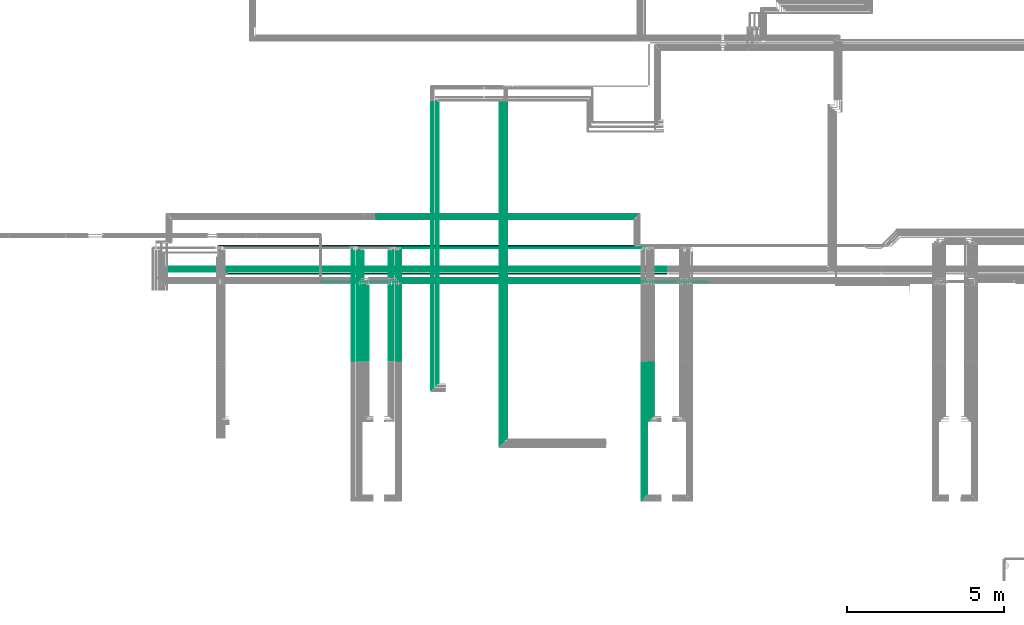
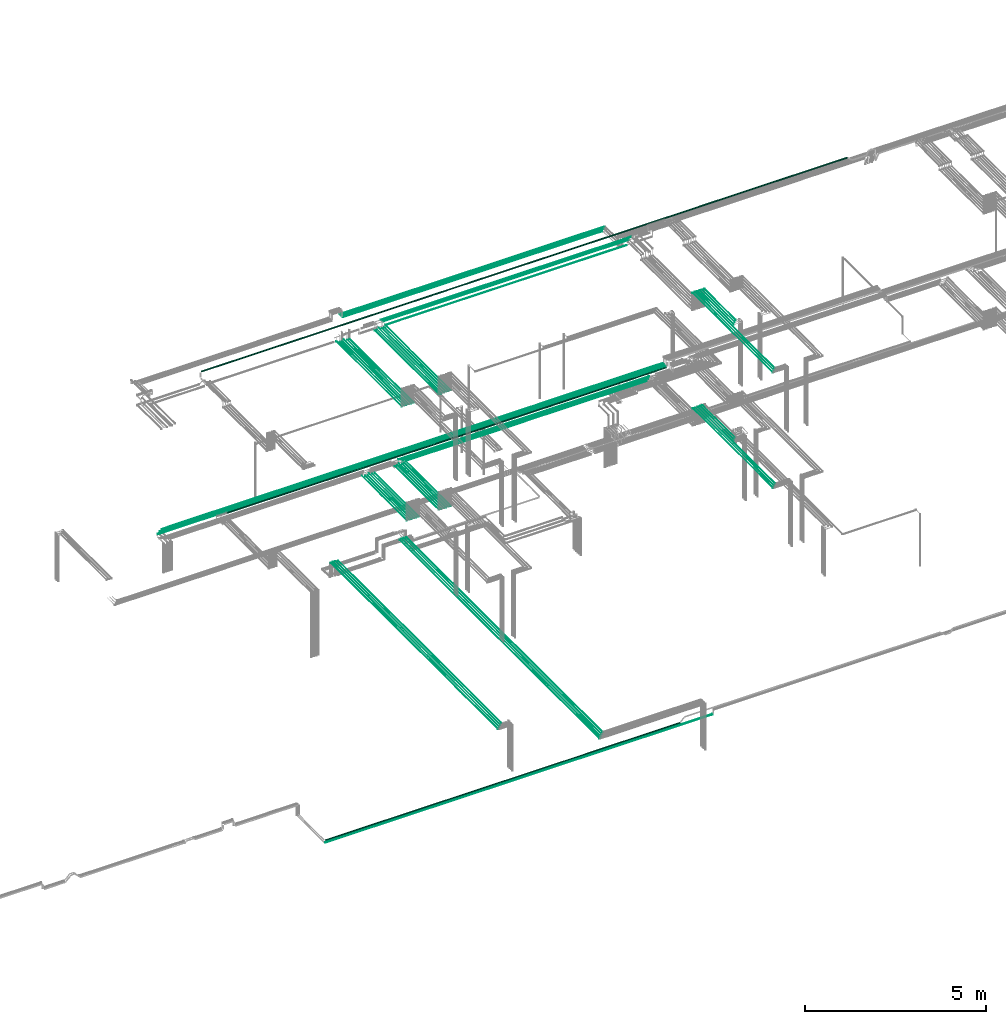
# One storey, part 16 of 331: 59 flow segments.
"""IFC2X3 building model written with IfcOpenShell, lengths in millimetres."""

from ifc_helpers import new_model, entity, si_unit, converted_unit, derived_unit, direction, frame, frame_2d, origin, origin_2d_with_axis, place, context, subcontext, project, spatial, circle, extrude, type_object, element, save


model = new_model("IFC2X3")

# Units and contexts
model_context = context("Model", 3, precision=0.01, world=origin(), true_north=direction((6.12303176911189e-17, 1.0)))
body_context = subcontext(model_context, "Body", "Model", "MODEL_VIEW")
ifc_project = project(units=[si_unit("LENGTHUNIT", "METRE", prefix="MILLI"), si_unit("AREAUNIT", "SQUARE_METRE"), si_unit("VOLUMEUNIT", "CUBIC_METRE"), converted_unit("PLANEANGLEUNIT", "DEGREE", entity("IfcRatioMeasure", 0.0174532925199433), si_unit("PLANEANGLEUNIT", "RADIAN"), dimensions=[0, 0, 0, 0, 0, 0, 0]), si_unit("MASSUNIT", "GRAM", prefix="KILO"), derived_unit("MASSDENSITYUNIT", [(si_unit("MASSUNIT", "GRAM", prefix="KILO"), 1), (si_unit("LENGTHUNIT", "METRE"), -3)]), derived_unit("MOMENTOFINERTIAUNIT", [(si_unit("LENGTHUNIT", "METRE"), 4)]), si_unit("TIMEUNIT", "SECOND"), si_unit("FREQUENCYUNIT", "HERTZ"), si_unit("THERMODYNAMICTEMPERATUREUNIT", "DEGREE_CELSIUS"), derived_unit("THERMALTRANSMITTANCEUNIT", [(si_unit("MASSUNIT", "GRAM", prefix="KILO"), 1), (si_unit("THERMODYNAMICTEMPERATUREUNIT", "KELVIN"), -1), (si_unit("TIMEUNIT", "SECOND"), -3)]), derived_unit("VOLUMETRICFLOWRATEUNIT", [(si_unit("LENGTHUNIT", "METRE"), 3), (si_unit("TIMEUNIT", "SECOND"), -1)]), derived_unit("MASSFLOWRATEUNIT", [(si_unit("MASSUNIT", "GRAM", prefix="KILO"), 1), (si_unit("TIMEUNIT", "SECOND"), -1)]), derived_unit("ROTATIONALFREQUENCYUNIT", [(si_unit("TIMEUNIT", "SECOND"), -1)]), si_unit("ELECTRICCURRENTUNIT", "AMPERE"), si_unit("ELECTRICVOLTAGEUNIT", "VOLT"), si_unit("POWERUNIT", "WATT"), si_unit("FORCEUNIT", "NEWTON", prefix="KILO"), si_unit("ILLUMINANCEUNIT", "LUX"), si_unit("LUMINOUSFLUXUNIT", "LUMEN"), si_unit("LUMINOUSINTENSITYUNIT", "CANDELA"), derived_unit("USERDEFINED", [(si_unit("MASSUNIT", "GRAM", prefix="KILO"), -1), (si_unit("LENGTHUNIT", "METRE"), -2), (si_unit("TIMEUNIT", "SECOND"), 3), (si_unit("LUMINOUSFLUXUNIT", "LUMEN"), 1)]), derived_unit("LINEARVELOCITYUNIT", [(si_unit("LENGTHUNIT", "METRE"), 1), (si_unit("TIMEUNIT", "SECOND"), -1)]), si_unit("PRESSUREUNIT", "PASCAL"), derived_unit("USERDEFINED", [(si_unit("LENGTHUNIT", "METRE"), -2), (si_unit("MASSUNIT", "GRAM", prefix="KILO"), 1), (si_unit("TIMEUNIT", "SECOND"), -2)]), derived_unit("LINEARFORCEUNIT", [(si_unit("MASSUNIT", "GRAM", prefix="KILO"), 1), (si_unit("LENGTHUNIT", "METRE"), 1), (si_unit("TIMEUNIT", "SECOND"), -2), (si_unit("LENGTHUNIT", "METRE"), -1)]), derived_unit("PLANARFORCEUNIT", [(si_unit("MASSUNIT", "GRAM", prefix="KILO"), 1), (si_unit("LENGTHUNIT", "METRE"), 1), (si_unit("TIMEUNIT", "SECOND"), -2), (si_unit("LENGTHUNIT", "METRE"), -2)])], contexts=[model_context])

# Site, building, storey
site_placement = place(None, frame((0.0, -0.00077364408347762, 0.0)))
site = spatial("IfcSite", under=ifc_project, at=site_placement, CompositionType="ELEMENT")
building_placement = place(site_placement, origin())
building = spatial("IfcBuilding", under=site, at=building_placement, CompositionType="ELEMENT")
storey_placement = place(building_placement, origin())
storey = spatial("IfcBuildingStorey", under=building, at=storey_placement, CompositionType="ELEMENT", Elevation=0.0)

# Flow segments
pipe_segment_type = type_object("IfcPipeSegmentType", PredefinedType="NOTDEFINED")
flow_segment_1_placement = place(storey_placement, frame((18995.3690702608, 8668.02529159145, 14542.4047277641)))
element("IfcFlowSegment", 1, at=flow_segment_1_placement, inside=storey, type_object=pipe_segment_type, context=body_context, shape_type="SweptSolid", body=[
    extrude(circle(Radius=6.0, at=frame_2d((0.0, 2.16573425859679e-12), x_axis=(1.0, 0.0))), frame((0.0, 7.59527223591562, 7.59527223591887), z_axis=(1.0, 0.0, 0.0), x_axis=(0.0, -1.0, 0.0)), (0.0, 0.0, 1.0), 15986.7114812012),
])
flow_segment_2_placement = place(storey_placement, frame((18796.253057284, 8513.02529159144, 14537.4047277641)))
element("IfcFlowSegment", 2, at=flow_segment_2_placement, inside=storey, type_object=pipe_segment_type, context=body_context, shape_type="SweptSolid", body=[
    extrude(circle(Radius=11.0, at=frame_2d((0.0, 2.16573425859679e-12), x_axis=(1.0, 0.0))), frame((0.0, 12.5952722359156, 12.5952722359177), z_axis=(1.0, 0.0, 0.0), x_axis=(0.0, -1.0, 0.0)), (0.0, 0.0, 1.0), 16175.8274941781),
])
flow_segment_3_placement = place(storey_placement, frame((18890.8110637724, 8593.02529159146, 14542.4047277641)))
element("IfcFlowSegment", 3, at=flow_segment_3_placement, inside=storey, type_object=pipe_segment_type, context=body_context, shape_type="SweptSolid", body=[
    extrude(circle(Radius=6.0, at=frame_2d((0.0, -2.16573425859679e-12), x_axis=(1.0, 0.0))), frame((0.0, 7.59527223591562, 7.59527223591454), z_axis=(1.0, 0.0, 0.0), x_axis=(0.0, -1.0, 0.0)), (0.0, 0.0, 1.0), 16091.2694876896),
])
flow_segment_4_placement = place(storey_placement, frame((20954.1118832776, 8431.52529159144, 14530.9047277637)))
element("IfcFlowSegment", 4, at=flow_segment_4_placement, inside=storey, type_object=pipe_segment_type, context=body_context, shape_type="SweptSolid", body=[
    extrude(circle(Radius=17.5, at=frame_2d((-5.41433564649196e-12, 0.0), x_axis=(1.0, 0.0))), frame((0.0, 19.0952722359217, 19.0952722359163), z_axis=(1.0, 0.0, 0.0), x_axis=(0.0, 1.0, 0.0)), (0.0, 0.0, 1.0), 14001.9686681844),
])
flow_segment_5_placement = place(storey_placement, frame((34326.5132627125, 1365.48876707917, 15142.4047277641)))
element("IfcFlowSegment", 5, at=flow_segment_5_placement, inside=storey, type_object=pipe_segment_type, context=body_context, shape_type="SweptSolid", body=[
    extrude(circle(Radius=6.0, at=frame_2d((0.0, 2.16573425859679e-12), x_axis=(1.0, 0.0))), frame((7.59527223591454, 0.0, 7.59527223591887), z_axis=(0.0, 1.0, 0.0), x_axis=(1.0, 0.0, 0.0)), (0.0, 0.0, 1.0), 4264.13179674823),
])
flow_segment_6_placement = place(storey_placement, frame((34253.5132627125, 1286.48876707975, 15144.4047277641)))
element("IfcFlowSegment", 6, at=flow_segment_6_placement, inside=storey, type_object=pipe_segment_type, context=body_context, shape_type="SweptSolid", body=[
    extrude(circle(Radius=4.0, at=origin_2d_with_axis()), frame((5.59527223591499, 0.0, 5.59527223591499), z_axis=(0.0, 1.0, 0.0), x_axis=(1.0, 0.0, 0.0)), (0.0, 0.0, 1.0), 4347.13179674765),
])
flow_segment_7_placement = place(storey_placement, frame((34178.5132627125, 1211.48876707933, 15144.4047277641)))
element("IfcFlowSegment", 7, at=flow_segment_7_placement, inside=storey, type_object=pipe_segment_type, context=body_context, shape_type="SweptSolid", body=[
    extrude(circle(Radius=4.0, at=origin_2d_with_axis()), frame((5.59527223591499, 0.0, 5.59527223591499), z_axis=(0.0, 1.0, 0.0), x_axis=(1.0, 0.0, 0.0)), (0.0, 0.0, 1.0), 4422.13179674807),
])
flow_segment_8_placement = place(storey_placement, frame((34478.5132627125, 3826.48876707975, 15144.4047277641)))
element("IfcFlowSegment", 8, at=flow_segment_8_placement, inside=storey, type_object=pipe_segment_type, context=body_context, shape_type="SweptSolid", body=[
    extrude(circle(Radius=4.0, at=origin_2d_with_axis()), frame((5.59527223591499, 0.0, 5.59527223591499), z_axis=(0.0, 1.0, 0.0), x_axis=(1.0, 0.0, 0.0)), (0.0, 0.0, 1.0), 1807.13179674766),
])
flow_segment_9_placement = place(storey_placement, frame((34403.5132627125, 3751.48876707907, 15144.4047277641)))
element("IfcFlowSegment", 9, at=flow_segment_9_placement, inside=storey, type_object=pipe_segment_type, context=body_context, shape_type="SweptSolid", body=[
    extrude(circle(Radius=4.0, at=origin_2d_with_axis()), frame((5.59527223591499, 0.0, 5.59527223591499), z_axis=(0.0, 1.0, 0.0), x_axis=(1.0, 0.0, 0.0)), (0.0, 0.0, 1.0), 1882.13179674834),
])
flow_segment_10_placement = place(storey_placement, frame((26240.5132663482, 5653.62056382741, 14544.4047277641)))
element("IfcFlowSegment", 10, at=flow_segment_10_placement, inside=storey, type_object=pipe_segment_type, context=body_context, shape_type="SweptSolid", body=[
    extrude(circle(Radius=4.0, at=frame_2d((4.33146851719357e-12, 0.0), x_axis=(1.0, 0.0))), frame((5.59527223591932, 0.0, 5.59527223591499), z_axis=(0.0, 1.0, 0.0), x_axis=(-1.0, 0.0, 0.0)), (0.0, 0.0, 1.0), 2489.38938002185),
])
flow_segment_11_placement = place(storey_placement, frame((26465.5132663482, 5653.62056382741, 14544.4047277641)))
element("IfcFlowSegment", 11, at=flow_segment_11_placement, inside=storey, type_object=pipe_segment_type, context=body_context, shape_type="SweptSolid", body=[
    extrude(circle(Radius=4.0, at=frame_2d((4.33146851719357e-12, 0.0), x_axis=(1.0, 0.0))), frame((5.59527223591932, 0.0, 5.59527223591499), z_axis=(0.0, 1.0, 0.0), x_axis=(-1.0, 0.0, 0.0)), (0.0, 0.0, 1.0), 2489.38938002186),
])
flow_segment_12_placement = place(storey_placement, frame((26165.5132663482, 5653.62056382741, 14544.4047277641)))
element("IfcFlowSegment", 12, at=flow_segment_12_placement, inside=storey, type_object=pipe_segment_type, context=body_context, shape_type="SweptSolid", body=[
    extrude(circle(Radius=4.0, at=origin_2d_with_axis()), frame((5.59527223591499, 0.0, 5.59527223591499), z_axis=(0.0, 1.0, 0.0), x_axis=(-1.0, 0.0, 0.0)), (0.0, 0.0, 1.0), 2426.52868594875),
])
flow_segment_13_placement = place(storey_placement, frame((26390.5132663482, 5653.62056382741, 14544.4047277641)))
element("IfcFlowSegment", 13, at=flow_segment_13_placement, inside=storey, type_object=pipe_segment_type, context=body_context, shape_type="SweptSolid", body=[
    extrude(circle(Radius=4.0, at=origin_2d_with_axis()), frame((5.59527223591499, 0.0, 5.59527223591499), z_axis=(0.0, 1.0, 0.0), x_axis=(-1.0, 0.0, 0.0)), (0.0, 0.0, 1.0), 2426.52868594876),
])
flow_segment_14_placement = place(storey_placement, frame((26088.5132663482, 5657.62056382741, 14542.4047277641)))
element("IfcFlowSegment", 14, at=flow_segment_14_placement, inside=storey, type_object=pipe_segment_type, context=body_context, shape_type="SweptSolid", body=[
    extrude(circle(Radius=6.0, at=frame_2d((8.66293703438714e-12, -2.16573425859679e-12), x_axis=(1.0, 0.0))), frame((7.5952722359232, 0.0, 7.59527223591887), z_axis=(0.0, 1.0, 0.0), x_axis=(-1.0, 0.0, 0.0)), (0.0, 0.0, 1.0), 2418.52868594877),
])
flow_segment_15_placement = place(storey_placement, frame((26313.5132663482, 5657.62056382741, 14542.4047277641)))
element("IfcFlowSegment", 15, at=flow_segment_15_placement, inside=storey, type_object=pipe_segment_type, context=body_context, shape_type="SweptSolid", body=[
    extrude(circle(Radius=6.0, at=frame_2d((0.0, -2.16573425859679e-12), x_axis=(1.0, 0.0))), frame((7.59527223591454, 0.0, 7.59527223591887), z_axis=(0.0, 1.0, 0.0), x_axis=(-1.0, 0.0, 0.0)), (0.0, 0.0, 1.0), 2418.52868594875),
])
flow_segment_16_placement = place(storey_placement, frame((25290.5132663482, 5653.62056382741, 14544.4047277641)))
element("IfcFlowSegment", 16, at=flow_segment_16_placement, inside=storey, type_object=pipe_segment_type, context=body_context, shape_type="SweptSolid", body=[
    extrude(circle(Radius=4.0, at=frame_2d((-8.66293703438714e-12, 0.0), x_axis=(1.0, 0.0))), frame((5.59527223592365, 0.0, 5.59527223591499), z_axis=(0.0, 1.0, 0.0), x_axis=(-1.0, 0.0, 0.0)), (0.0, 0.0, 1.0), 2489.38938002184),
])
flow_segment_17_placement = place(storey_placement, frame((25065.5132663482, 5653.62056382741, 14544.4047277641)))
element("IfcFlowSegment", 17, at=flow_segment_17_placement, inside=storey, type_object=pipe_segment_type, context=body_context, shape_type="SweptSolid", body=[
    extrude(circle(Radius=4.0, at=frame_2d((-8.66293703438714e-12, 0.0), x_axis=(1.0, 0.0))), frame((5.59527223592365, 0.0, 5.59527223591499), z_axis=(0.0, 1.0, 0.0), x_axis=(-1.0, 0.0, 0.0)), (0.0, 0.0, 1.0), 2489.38938002183),
])
flow_segment_18_placement = place(storey_placement, frame((25365.5132663482, 5653.62056382741, 14544.4047277641)))
element("IfcFlowSegment", 18, at=flow_segment_18_placement, inside=storey, type_object=pipe_segment_type, context=body_context, shape_type="SweptSolid", body=[
    extrude(circle(Radius=4.0, at=origin_2d_with_axis()), frame((5.59527223591499, 0.0, 5.59527223591499), z_axis=(0.0, 1.0, 0.0), x_axis=(-1.0, 0.0, 0.0)), (0.0, 0.0, 1.0), 2426.52868594875),
])
flow_segment_19_placement = place(storey_placement, frame((25140.5132663482, 5653.62056382741, 14544.4047277641)))
element("IfcFlowSegment", 19, at=flow_segment_19_placement, inside=storey, type_object=pipe_segment_type, context=body_context, shape_type="SweptSolid", body=[
    extrude(circle(Radius=4.0, at=origin_2d_with_axis()), frame((5.59527223591499, 0.0, 5.59527223591499), z_axis=(0.0, 1.0, 0.0), x_axis=(-1.0, 0.0, 0.0)), (0.0, 0.0, 1.0), 2426.52868594876),
])
flow_segment_20_placement = place(storey_placement, frame((25438.5132663482, 5657.62056382741, 14542.4047277641)))
element("IfcFlowSegment", 20, at=flow_segment_20_placement, inside=storey, type_object=pipe_segment_type, context=body_context, shape_type="SweptSolid", body=[
    extrude(circle(Radius=6.0, at=frame_2d((-8.66293703438714e-12, -2.16573425859679e-12), x_axis=(1.0, 0.0))), frame((7.5952722359232, 0.0, 7.59527223591887), z_axis=(0.0, 1.0, 0.0), x_axis=(-1.0, 0.0, 0.0)), (0.0, 0.0, 1.0), 2418.52868594877),
])
flow_segment_21_placement = place(storey_placement, frame((25213.5132663482, 5657.62056382741, 14542.4047277641)))
element("IfcFlowSegment", 21, at=flow_segment_21_placement, inside=storey, type_object=pipe_segment_type, context=body_context, shape_type="SweptSolid", body=[
    extrude(circle(Radius=6.0, at=frame_2d((0.0, -2.16573425859679e-12), x_axis=(1.0, 0.0))), frame((7.59527223591454, 0.0, 7.59527223591887), z_axis=(0.0, 1.0, 0.0), x_axis=(-1.0, 0.0, 0.0)), (0.0, 0.0, 1.0), 2418.52868594875),
])
flow_segment_22_placement = place(storey_placement, frame((26478.1085385841, 8148.41467161335, 14542.4047277641)))
element("IfcFlowSegment", 22, at=flow_segment_22_placement, inside=storey, type_object=pipe_segment_type, context=body_context, shape_type="SweptSolid", body=[
    extrude(circle(Radius=6.0, at=frame_2d((4.33146851719357e-12, 0.0), x_axis=(1.0, 0.0))), frame((0.0, 7.59527223591995, 7.5952722359167), z_axis=(1.0, 0.0, 0.0), x_axis=(0.0, 1.0, 0.0)), (0.0, 0.0, 1.0), 7698.9999963643),
])
flow_segment_23_placement = place(storey_placement, frame((26403.1085425053, 8223.41467161342, 14542.4040565394)))
element("IfcFlowSegment", 23, at=flow_segment_23_placement, inside=storey, type_object=pipe_segment_type, context=body_context, shape_type="SweptSolid", body=[
    extrude(circle(Radius=6.0, at=frame_2d((-1.08286712929839e-12, 0.0), x_axis=(1.0, 0.0))), frame((0.0, 7.5952722359167, 7.5952722359167), z_axis=(1.0, 0.0, 0.0), x_axis=(0.0, 1.0, 0.0)), (0.0, 0.0, 1.0), 7848.99999636428),
])
flow_segment_24_placement = place(storey_placement, frame((26329.1085341706, 8296.91467161341, 14540.9038014742)))
element("IfcFlowSegment", 24, at=flow_segment_24_placement, inside=storey, type_object=pipe_segment_type, context=body_context, shape_type="SweptSolid", body=[
    extrude(circle(Radius=7.5, at=frame_2d((-1.08286712929839e-12, 2.16573425859679e-12), x_axis=(1.0, 0.0))), frame((0.0, 9.09527223591744, 9.09527223591419), z_axis=(1.0, 0.0, 0.0), x_axis=(0.0, 1.0, 0.0)), (0.0, 0.0, 1.0), 7996.99999636427),
])
flow_segment_25_placement = place(storey_placement, frame((27663.5853972626, 4949.0, 7242.40472776408)))
element("IfcFlowSegment", 25, at=flow_segment_25_placement, inside=storey, type_object=pipe_segment_type, context=body_context, shape_type="SweptSolid", body=[
    extrude(circle(Radius=6.0, at=frame_2d((7.89476087863008e-41, 1.40772726808791e-11), x_axis=(1.0, 0.0))), frame((7.59527223591454, 0.0, 7.5952722359297), z_axis=(0.0, 1.0, 0.0), x_axis=(-1.0, 0.0, 0.0)), (0.0, 0.0, 1.0), 8999.11190463198),
])
flow_segment_26_placement = place(storey_placement, frame((27590.5853972626, 4870.0, 7244.40472776409)))
element("IfcFlowSegment", 26, at=flow_segment_26_placement, inside=storey, type_object=pipe_segment_type, context=body_context, shape_type="SweptSolid", body=[
    extrude(circle(Radius=4.0, at=origin_2d_with_axis()), frame((5.59527223591499, 0.0, 5.59527223591607), z_axis=(0.0, 1.0, 0.0), x_axis=(1.0, 0.0, 0.0)), (0.0, 0.0, 1.0), 9104.99967040982),
])
flow_segment_27_placement = place(storey_placement, frame((27515.5853972625, 4795.0, 7244.40472776409)))
element("IfcFlowSegment", 27, at=flow_segment_27_placement, inside=storey, type_object=pipe_segment_type, context=body_context, shape_type="SweptSolid", body=[
    extrude(circle(Radius=4.0, at=origin_2d_with_axis()), frame((5.59527223591066, 0.0, 5.59527223591607), z_axis=(0.0, 1.0, 0.0), x_axis=(1.0, 0.0, 0.0)), (0.0, 0.0, 1.0), 9179.99967040981),
])
flow_segment_28_placement = place(storey_placement, frame((27437.0853972625, 4728.0, 7240.90472776409)))
element("IfcFlowSegment", 28, at=flow_segment_28_placement, inside=storey, type_object=pipe_segment_type, context=body_context, shape_type="SweptSolid", body=[
    extrude(circle(Radius=7.5, at=origin_2d_with_axis()), frame((9.09527223591419, 0.0, 9.09527223591636), z_axis=(0.0, 1.0, 0.0), x_axis=(1.0, 0.0, 0.0)), (0.0, 0.0, 1.0), 9221.99967040982),
])
flow_segment_29_placement = place(storey_placement, frame((29633.4411281624, 2933.37515048574, 7242.40472776409)))
element("IfcFlowSegment", 29, at=flow_segment_29_placement, inside=storey, type_object=pipe_segment_type, context=body_context, shape_type="SweptSolid", body=[
    extrude(circle(Radius=6.0, at=origin_2d_with_axis()), frame((7.59527223591454, 0.0, 7.59527223591562), z_axis=(0.0, 1.0, 0.0), x_axis=(1.0, 0.0, 0.0)), (0.0, 0.0, 1.0), 11029.2052767451),
])
flow_segment_30_placement = place(storey_placement, frame((29710.4411281624, 3004.37515048583, 7244.4047277641)))
element("IfcFlowSegment", 30, at=flow_segment_30_placement, inside=storey, type_object=pipe_segment_type, context=body_context, shape_type="SweptSolid", body=[
    extrude(circle(Radius=4.0, at=frame_2d((8.55899912808306e-41, 1.62430069394759e-11), x_axis=(1.0, 0.0))), frame((5.59527223591499, 0.0, 5.5952722359334), z_axis=(0.0, 1.0, 0.0), x_axis=(-1.0, 0.0, 0.0)), (0.0, 0.0, 1.0), 10995.7541581332),
])
flow_segment_31_placement = place(storey_placement, frame((29785.4411281624, 3079.3751504857, 7244.40472776408)))
element("IfcFlowSegment", 31, at=flow_segment_31_placement, inside=storey, type_object=pipe_segment_type, context=body_context, shape_type="SweptSolid", body=[
    extrude(circle(Radius=4.0, at=origin_2d_with_axis()), frame((5.59527223591066, 0.0, 5.59527223591607), z_axis=(0.0, 1.0, 0.0), x_axis=(1.0, 0.0, 0.0)), (0.0, 0.0, 1.0), 10920.6245199245),
])
flow_segment_32_placement = place(storey_placement, frame((29856.9411281624, 3162.3751504856, 7240.9047277641)))
element("IfcFlowSegment", 32, at=flow_segment_32_placement, inside=storey, type_object=pipe_segment_type, context=body_context, shape_type="SweptSolid", body=[
    extrude(circle(Radius=7.5, at=frame_2d((-4.33146851719357e-12, 1.94916083273711e-11), x_axis=(1.0, 0.0))), frame((9.09527223590986, 0.0, 9.09527223593477), z_axis=(0.0, 1.0, 0.0), x_axis=(-1.0, 0.0, 0.0)), (0.0, 0.0, 1.0), 10810.1986360677),
])
flow_segment_33_placement = place(storey_placement, frame((26329.3289275939, 9265.90472776411, 18665.9047277641)))
element("IfcFlowSegment", 33, at=flow_segment_33_placement, inside=storey, type_object=pipe_segment_type, context=body_context, shape_type="SweptSolid", body=[
    extrude(circle(Radius=7.5, at=frame_2d((-3.46517481375486e-11, 0.0), x_axis=(1.0, 0.0))), frame((0.0, 9.09527223595101, 9.09527223591636), z_axis=(1.0, 0.0, 0.0), x_axis=(0.0, 1.0, 0.0)), (0.0, 0.0, 1.0), 7983.72222195128),
])
flow_segment_34_placement = place(storey_placement, frame((34313.4558773093, 1365.48876707969, 19042.4047277641)))
element("IfcFlowSegment", 34, at=flow_segment_34_placement, inside=storey, type_object=pipe_segment_type, context=body_context, shape_type="SweptSolid", body=[
    extrude(circle(Radius=6.0, at=origin_2d_with_axis()), frame((7.59527223591454, 0.0, 7.5952722359167), z_axis=(0.0, 1.0, 0.0), x_axis=(1.0, 0.0, 0.0)), (0.0, 0.0, 1.0), 4264.13179674766),
])
flow_segment_35_placement = place(storey_placement, frame((34538.4558773093, 3905.4887670797, 19042.4047277641)))
element("IfcFlowSegment", 35, at=flow_segment_35_placement, inside=storey, type_object=pipe_segment_type, context=body_context, shape_type="SweptSolid", body=[
    extrude(circle(Radius=6.0, at=origin_2d_with_axis()), frame((7.59527223591454, 0.0, 7.5952722359167), z_axis=(0.0, 1.0, 0.0), x_axis=(1.0, 0.0, 0.0)), (0.0, 0.0, 1.0), 1724.13179674766),
])
flow_segment_36_placement = place(storey_placement, frame((34240.4558773093, 1286.48876707969, 19044.4047277641)))
element("IfcFlowSegment", 36, at=flow_segment_36_placement, inside=storey, type_object=pipe_segment_type, context=body_context, shape_type="SweptSolid", body=[
    extrude(circle(Radius=4.0, at=origin_2d_with_axis()), frame((5.59527223591499, 0.0, 5.59527223591499), z_axis=(0.0, 1.0, 0.0), x_axis=(1.0, 0.0, 0.0)), (0.0, 0.0, 1.0), 4347.13179674766),
])
flow_segment_37_placement = place(storey_placement, frame((34165.4558773093, 1211.48876707969, 19044.4047277641)))
element("IfcFlowSegment", 37, at=flow_segment_37_placement, inside=storey, type_object=pipe_segment_type, context=body_context, shape_type="SweptSolid", body=[
    extrude(circle(Radius=4.0, at=origin_2d_with_axis()), frame((5.59527223591499, 0.0, 5.59527223591499), z_axis=(0.0, 1.0, 0.0), x_axis=(1.0, 0.0, 0.0)), (0.0, 0.0, 1.0), 4422.13179674766),
])
flow_segment_38_placement = place(storey_placement, frame((34465.4558773093, 3826.48876707969, 19044.4047277641)))
element("IfcFlowSegment", 38, at=flow_segment_38_placement, inside=storey, type_object=pipe_segment_type, context=body_context, shape_type="SweptSolid", body=[
    extrude(circle(Radius=4.0, at=origin_2d_with_axis()), frame((5.59527223591499, 0.0, 5.59527223591499), z_axis=(0.0, 1.0, 0.0), x_axis=(1.0, 0.0, 0.0)), (0.0, 0.0, 1.0), 1807.13179674766),
])
flow_segment_39_placement = place(storey_placement, frame((34390.4558773093, 3751.48876707969, 19044.4047277641)))
element("IfcFlowSegment", 39, at=flow_segment_39_placement, inside=storey, type_object=pipe_segment_type, context=body_context, shape_type="SweptSolid", body=[
    extrude(circle(Radius=4.0, at=origin_2d_with_axis()), frame((5.59527223591499, 0.0, 5.59527223591499), z_axis=(0.0, 1.0, 0.0), x_axis=(1.0, 0.0, 0.0)), (0.0, 0.0, 1.0), 1882.13179674766),
])
flow_segment_40_placement = place(storey_placement, frame((26240.733655358, 5653.62056382734, 18444.4047277641)))
element("IfcFlowSegment", 40, at=flow_segment_40_placement, inside=storey, type_object=pipe_segment_type, context=body_context, shape_type="SweptSolid", body=[
    extrude(circle(Radius=4.0, at=origin_2d_with_axis()), frame((5.59527223591499, 0.0, 5.59527223591499), z_axis=(0.0, 1.0, 0.0), x_axis=(-1.0, 0.0, 0.0)), (0.0, 0.0, 1.0), 3608.37943617269),
])
flow_segment_41_placement = place(storey_placement, frame((26465.733655358, 5653.62056382734, 18444.4047277641)))
element("IfcFlowSegment", 41, at=flow_segment_41_placement, inside=storey, type_object=pipe_segment_type, context=body_context, shape_type="SweptSolid", body=[
    extrude(circle(Radius=4.0, at=frame_2d((4.33146851719357e-12, 0.0), x_axis=(1.0, 0.0))), frame((5.59527223591499, 0.0, 5.59527223591499), z_axis=(0.0, 1.0, 0.0), x_axis=(-1.0, 0.0, 0.0)), (0.0, 0.0, 1.0), 3608.37943617269),
])
flow_segment_42_placement = place(storey_placement, frame((26165.733655358, 5653.62056382734, 18444.4047277641)))
element("IfcFlowSegment", 42, at=flow_segment_42_placement, inside=storey, type_object=pipe_segment_type, context=body_context, shape_type="SweptSolid", body=[
    extrude(circle(Radius=4.0, at=origin_2d_with_axis()), frame((5.59527223591499, 0.0, 5.59527223591499), z_axis=(0.0, 1.0, 0.0), x_axis=(1.0, 0.0, 0.0)), (0.0, 0.0, 1.0), 3536.37943617272),
])
flow_segment_43_placement = place(storey_placement, frame((26390.733655358, 5653.62056382734, 18444.4047277641)))
element("IfcFlowSegment", 43, at=flow_segment_43_placement, inside=storey, type_object=pipe_segment_type, context=body_context, shape_type="SweptSolid", body=[
    extrude(circle(Radius=4.0, at=origin_2d_with_axis()), frame((5.59527223591499, 0.0, 5.59527223591499), z_axis=(0.0, 1.0, 0.0), x_axis=(1.0, 0.0, 0.0)), (0.0, 0.0, 1.0), 3536.37943617269),
])
flow_segment_44_placement = place(storey_placement, frame((26088.733655358, 5657.62056382736, 18442.4047277641)))
element("IfcFlowSegment", 44, at=flow_segment_44_placement, inside=storey, type_object=pipe_segment_type, context=body_context, shape_type="SweptSolid", body=[
    extrude(circle(Radius=6.0, at=origin_2d_with_axis()), frame((7.59527223591454, 0.0, 7.5952722359167), z_axis=(0.0, 1.0, 0.0), x_axis=(1.0, 0.0, 0.0)), (0.0, 0.0, 1.0), 3528.37943617268),
])
flow_segment_45_placement = place(storey_placement, frame((26313.733655358, 5657.62056382734, 18442.4047277641)))
element("IfcFlowSegment", 45, at=flow_segment_45_placement, inside=storey, type_object=pipe_segment_type, context=body_context, shape_type="SweptSolid", body=[
    extrude(circle(Radius=6.0, at=origin_2d_with_axis()), frame((7.59527223591454, 0.0, 7.5952722359167), z_axis=(0.0, 1.0, 0.0), x_axis=(1.0, 0.0, 0.0)), (0.0, 0.0, 1.0), 3528.37943617277),
])
flow_segment_46_placement = place(storey_placement, frame((25128.7436346567, 5653.62056382734, 18444.404727764)))
element("IfcFlowSegment", 46, at=flow_segment_46_placement, inside=storey, type_object=pipe_segment_type, context=body_context, shape_type="SweptSolid", body=[
    extrude(circle(Radius=4.0, at=frame_2d((-4.33146851719357e-12, 0.0), x_axis=(1.0, 0.0))), frame((5.59527223591499, 0.0, 5.59527223591499), z_axis=(0.0, 1.0, 0.0), x_axis=(-1.0, 0.0, 0.0)), (0.0, 0.0, 1.0), 3611.37943617273),
])
flow_segment_47_placement = place(storey_placement, frame((24903.7436346567, 5653.62056382734, 18444.404727764)))
element("IfcFlowSegment", 47, at=flow_segment_47_placement, inside=storey, type_object=pipe_segment_type, context=body_context, shape_type="SweptSolid", body=[
    extrude(circle(Radius=4.0, at=frame_2d((-4.33146851719357e-12, 0.0), x_axis=(1.0, 0.0))), frame((5.59527223591499, 0.0, 5.59527223591499), z_axis=(0.0, 1.0, 0.0), x_axis=(-1.0, 0.0, 0.0)), (0.0, 0.0, 1.0), 3611.37943617274),
])
flow_segment_48_placement = place(storey_placement, frame((25203.7436346567, 5653.62087037021, 18444.4047277641)))
element("IfcFlowSegment", 48, at=flow_segment_48_placement, inside=storey, type_object=pipe_segment_type, context=body_context, shape_type="SweptSolid", body=[
    extrude(circle(Radius=4.0, at=frame_2d((4.33146851719357e-12, 0.0), x_axis=(1.0, 0.0))), frame((5.59527223591499, 0.0, 5.59527223591499), z_axis=(0.0, 1.0, 0.0), x_axis=(-1.0, 0.0, 0.0)), (0.0, 0.0, 1.0), 3536.37912962983),
])
flow_segment_49_placement = place(storey_placement, frame((24978.7436346567, 5653.62056382734, 18444.4047277641)))
element("IfcFlowSegment", 49, at=flow_segment_49_placement, inside=storey, type_object=pipe_segment_type, context=body_context, shape_type="SweptSolid", body=[
    extrude(circle(Radius=4.0, at=frame_2d((4.33146851719357e-12, 0.0), x_axis=(1.0, 0.0))), frame((5.59527223591499, 0.0, 5.59527223591499), z_axis=(0.0, 1.0, 0.0), x_axis=(-1.0, 0.0, 0.0)), (0.0, 0.0, 1.0), 3536.37943617269),
])
flow_segment_50_placement = place(storey_placement, frame((25276.7436346567, 5657.62056382736, 18442.4047277641)))
element("IfcFlowSegment", 50, at=flow_segment_50_placement, inside=storey, type_object=pipe_segment_type, context=body_context, shape_type="SweptSolid", body=[
    extrude(circle(Radius=6.0, at=origin_2d_with_axis()), frame((7.59527223591454, 0.0, 7.5952722359167), z_axis=(0.0, 1.0, 0.0), x_axis=(1.0, 0.0, 0.0)), (0.0, 0.0, 1.0), 3528.37943617268),
])
flow_segment_51_placement = place(storey_placement, frame((25051.7436346567, 5657.62056382734, 18442.4047277641)))
element("IfcFlowSegment", 51, at=flow_segment_51_placement, inside=storey, type_object=pipe_segment_type, context=body_context, shape_type="SweptSolid", body=[
    extrude(circle(Radius=6.0, at=origin_2d_with_axis()), frame((7.59527223591454, 0.0, 7.5952722359167), z_axis=(0.0, 1.0, 0.0), x_axis=(1.0, 0.0, 0.0)), (0.0, 0.0, 1.0), 3528.3794361727),
])
flow_segment_52_placement = place(storey_placement, frame((26478.328927594, 9267.40472776412, 18442.4047277641)))
element("IfcFlowSegment", 52, at=flow_segment_52_placement, inside=storey, type_object=pipe_segment_type, context=body_context, shape_type="SweptSolid", body=[
    extrude(circle(Radius=6.0, at=frame_2d((-1.08286712929839e-12, 0.0), x_axis=(1.0, 0.0))), frame((0.0, 7.59527223591454, 7.5952722359167), z_axis=(1.0, 0.0, 0.0), x_axis=(0.0, -1.0, 0.0)), (0.0, 0.0, 1.0), 7685.72222195127),
])
flow_segment_53_placement = place(storey_placement, frame((25651.7389068927, 10342.430236278, 18442.4047277641)))
element("IfcFlowSegment", 53, at=flow_segment_53_placement, inside=storey, type_object=pipe_segment_type, context=body_context, shape_type="SweptSolid", body=[
    extrude(circle(Radius=6.0, at=frame_2d((6.49720277579036e-12, -2.16573425859679e-12), x_axis=(1.0, 0.0))), frame((0.0, 7.59527223592536, 7.59527223591887), z_axis=(1.0, 0.0, 0.0), x_axis=(0.0, 1.0, 0.0)), (0.0, 0.0, 1.0), 8430.31224265255),
])
flow_segment_54_placement = place(storey_placement, frame((25651.7389068927, 10267.430236278, 18442.4047277641)))
element("IfcFlowSegment", 54, at=flow_segment_54_placement, inside=storey, type_object=pipe_segment_type, context=body_context, shape_type="SweptSolid", body=[
    extrude(circle(Radius=6.0, at=frame_2d((0.0, 2.16573425859679e-12), x_axis=(1.0, 0.0))), frame((0.0, 7.59527223593836, 7.59527223591887), z_axis=(1.0, 0.0, 0.0), x_axis=(0.0, -1.0, 0.0)), (0.0, 0.0, 1.0), 8355.31224265253),
])
flow_segment_55_placement = place(storey_placement, frame((25661.7389068927, 10187.430236278, 18437.4047277641)))
element("IfcFlowSegment", 55, at=flow_segment_55_placement, inside=storey, type_object=pipe_segment_type, context=body_context, shape_type="SweptSolid", body=[
    extrude(circle(Radius=11.0, at=frame_2d((0.0, 2.16573425859679e-12), x_axis=(1.0, 0.0))), frame((0.0, 12.5952722359372, 12.5952722359177), z_axis=(1.0, 0.0, 0.0), x_axis=(0.0, -1.0, 0.0)), (0.0, 0.0, 1.0), 8260.31224265254),
])
flow_segment_56_placement = place(storey_placement, frame((26403.328927594, 9267.40472776435, 18592.4047277641)))
element("IfcFlowSegment", 56, at=flow_segment_56_placement, inside=storey, type_object=pipe_segment_type, context=body_context, shape_type="SweptSolid", body=[
    extrude(circle(Radius=6.0, at=frame_2d((4.33146851719357e-12, 0.0), x_axis=(1.0, 0.0))), frame((0.0, 7.59527223591995, 7.5952722359167), z_axis=(1.0, 0.0, 0.0), x_axis=(0.0, 1.0, 0.0)), (0.0, 0.0, 1.0), 7835.72222195124),
])
flow_segment_57_placement = place(storey_placement, frame((20661.3273967077, 9330.9047277643, 18855.9047278307)))
element("IfcFlowSegment", 57, at=flow_segment_57_placement, inside=storey, type_object=pipe_segment_type, context=body_context, shape_type="SweptSolid", body=[
    extrude(circle(Radius=17.5, at=origin_2d_with_axis()), frame((0.00153088619078972, 19.0952722359163, 19.0952721689582), z_axis=(0.999999996173694, 0.0, 8.74792106541473e-05), x_axis=(0.0, 1.0, 0.0)), (0.0, 0.0, 1.0), 20580.2609484964),
])
flow_segment_58_placement = place(building_placement, frame((23948.4856518444, 8179.92098945675, 2609.40472776408)))
element("IfcFlowSegment", 58, at=flow_segment_58_placement, inside=storey, type_object=pipe_segment_type, context=body_context, shape_type="SweptSolid", body=[
    extrude(circle(Radius=14.0, at=frame_2d((3.24860138789518e-12, 0.0), x_axis=(1.0, 0.0))), frame((0.0, 15.5952722359192, 15.595272235916), z_axis=(1.0, 0.0, 0.0), x_axis=(0.0, 1.0, 0.0)), (0.0, 0.0, 1.0), 11299.3493391141),
])
flow_segment_59_placement = place(building_placement, frame((23938.4856518444, 8182.92098945675, 2537.40472776407)))
element("IfcFlowSegment", 59, at=flow_segment_59_placement, inside=storey, type_object=pipe_segment_type, context=body_context, shape_type="SweptSolid", body=[
    extrude(circle(Radius=11.0, at=frame_2d((2.16573425859679e-12, -5.41433564649196e-13), x_axis=(1.0, 0.0))), frame((0.0, 12.5952722359177, 12.5952722359166), z_axis=(1.0, 0.0, 0.0), x_axis=(0.0, 1.0, 0.0)), (0.0, 0.0, 1.0), 12343.8778697225),
])

save(model, "model.ifc")
